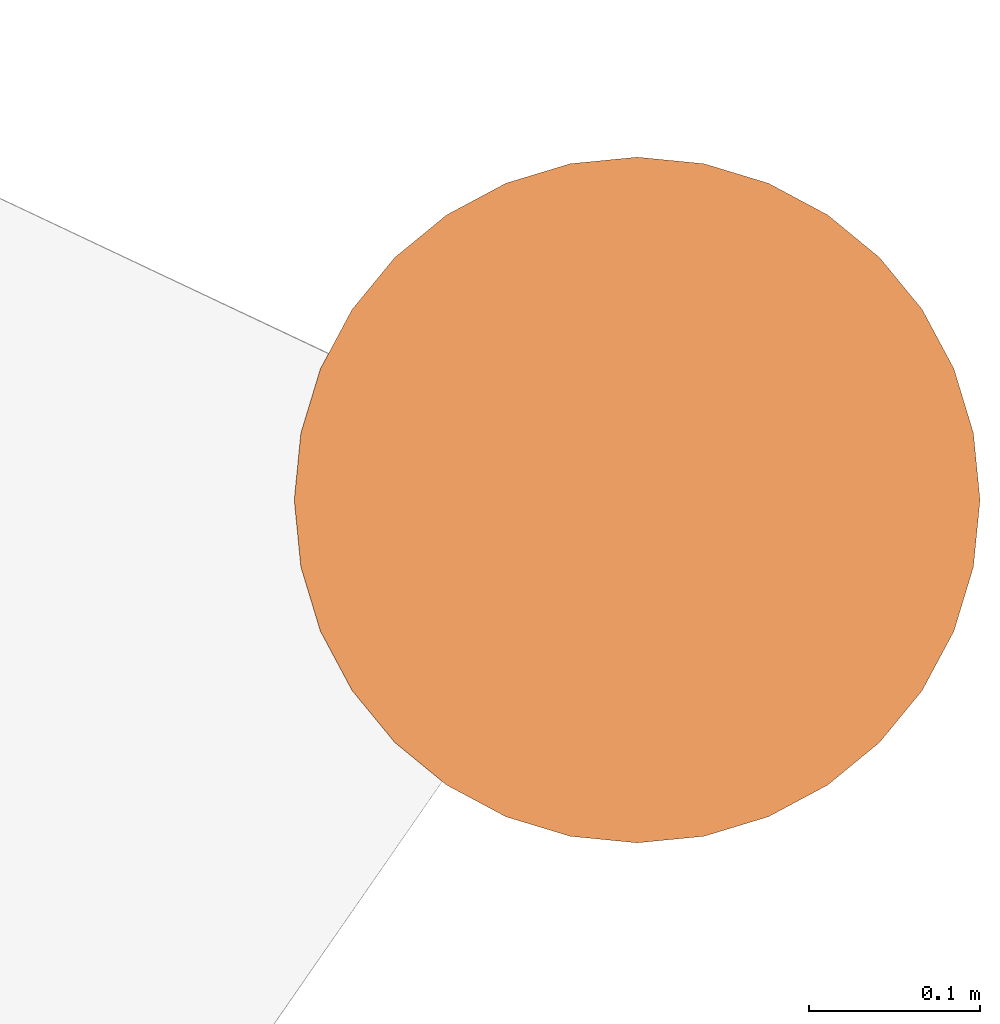
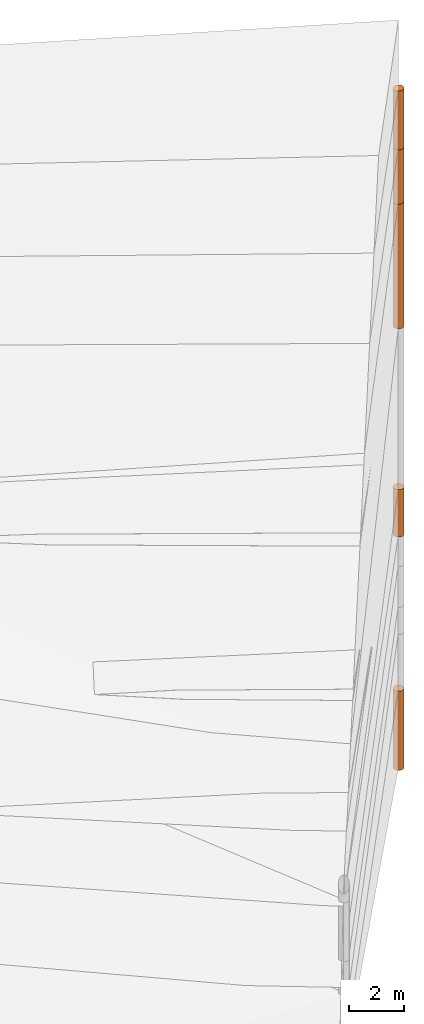
# One storey, part 20 of 24: 5 geographic elements.
"""IFC4 building model written with IfcOpenShell, lengths in metres."""

import ifcopenshell
import ifcopenshell.guid

model = None  # the IFC model being written
_history = None  # IfcOwnerHistory: only IFC2X3 demands one
_inside = {}  # id of a spatial element -> (the spatial element, [elements in it])
_under = {}  # id of a project, library or spatial element -> (it, [spatial elements below it])
_declared = {}  # id of a project -> (the project, [libraries it declares])
_typed = {}  # id of a type object -> (the type object, [elements of that type])
_made_of = {}  # id of a material, layer set ... -> (it, [elements and type objects made of it])


def new_model(schema):
    """Start an empty IFC model of exactly this schema.

    Asked for "IFC4X3", IfcOpenShell would pick the latest addendum, in which some entities
    have other attributes; the version numbers below select the first issue.
    IFC2X3 requires an IfcOwnerHistory on every rooted entity: one is made here for all.
    """
    global model, _history
    if schema == "IFC4X3":
        model = ifcopenshell.file(schema_version=(4, 3, 0, 0))
    else:
        model = ifcopenshell.file(schema=schema)
    _inside.clear()
    _under.clear()
    _declared.clear()
    _typed.clear()
    _made_of.clear()
    _history = None
    if model.schema == "IFC2X3":
        org = make("IfcOrganization", Name="unknown")
        user = make(
            "IfcPersonAndOrganization",
            ThePerson=make("IfcPerson", FamilyName="unknown"),
            TheOrganization=org,
        )
        app = make(
            "IfcApplication",
            ApplicationDeveloper=org,
            Version="unknown",
            ApplicationFullName="unknown",
            ApplicationIdentifier="unknown",
        )
        _history = make(
            "IfcOwnerHistory",
            OwningUser=user,
            OwningApplication=app,
            ChangeAction="ADDED",
            CreationDate=0,
        )
    return model


def make(cls, **values):
    """One entity of the class cls with the attributes given. An attribute that is None is left unset."""
    return model.create_entity(
        cls, **{name: value for name, value in values.items() if value is not None}
    )


def entity(cls, *values):
    """Any entity or typed value of the class cls, its attributes in the order of the schema. None: left unset."""
    e = model.create_entity(cls)
    for i, value in enumerate(values):
        if value is not None:
            e[i] = value
    return e


def rooted(cls, **values):
    """An entity with a GlobalId (a new one), such as an element, a storey or a relation."""
    return make(cls, GlobalId=ifcopenshell.guid.new(), OwnerHistory=_history, **values)


def si_unit(unit_type, name, prefix=None):
    """IfcSIUnit, for example si_unit("LENGTHUNIT", "METRE", prefix="MILLI")."""
    return make("IfcSIUnit", UnitType=unit_type, Prefix=prefix, Name=name)


def converted_unit(unit_type, name, factor, base, dimensions=None, offset=None):
    """IfcConversionBasedUnit, such as the inch: factor (a typed value) times the base unit."""
    return make(
        "IfcConversionBasedUnit"
        if offset is None
        else "IfcConversionBasedUnitWithOffset",
        ConversionOffset=offset,
        Dimensions=None
        if dimensions is None
        else entity("IfcDimensionalExponents", *dimensions),
        UnitType=unit_type,
        Name=name,
        ConversionFactor=make(
            "IfcMeasureWithUnit", ValueComponent=factor, UnitComponent=base
        ),
    )


def assignment(units):
    """IfcUnitAssignment: the units of a project."""
    return None if units is None else make("IfcUnitAssignment", Units=units)


def point(xyz):
    """IfcCartesianPoint."""
    return None if xyz is None else make("IfcCartesianPoint", Coordinates=xyz)


def direction(xyz):
    """IfcDirection."""
    return None if xyz is None else make("IfcDirection", DirectionRatios=xyz)


def frame(location, z_axis=None, x_axis=None):
    """IfcAxis2Placement3D, a coordinate frame: its origin and axes. An axis left out is left unset."""
    return make(
        "IfcAxis2Placement3D",
        Location=point(location),
        Axis=direction(z_axis),
        RefDirection=direction(x_axis),
    )


def frame_2d(location, x_axis=None):
    """IfcAxis2Placement2D, a coordinate frame in the plane: its origin and x axis."""
    return make(
        "IfcAxis2Placement2D", Location=point(location), RefDirection=direction(x_axis)
    )


def origin_with_axes():
    """The frame at (0, 0, 0) with the z axis (0, 0, 1) and the x axis (1, 0, 0) written out."""
    return frame((0.0, 0.0, 0.0), z_axis=(0.0, 0.0, 1.0), x_axis=(1.0, 0.0, 0.0))


def origin_2d_with_axis():
    """The frame at (0, 0) in the plane with the x axis (1, 0) written out."""
    return frame_2d((0.0, 0.0), x_axis=(1.0, 0.0))


def place(relative_to, where):
    """IfcLocalPlacement: puts the frame where relative to a parent placement (None: the world)."""
    return make(
        "IfcLocalPlacement", PlacementRelTo=relative_to, RelativePlacement=where
    )


def context(
    kind, dimensions, precision=None, world=None, true_north=None, identifier=None
):
    """IfcGeometricRepresentationContext, for example the 3D "Model" context."""
    return make(
        "IfcGeometricRepresentationContext",
        ContextIdentifier=identifier,
        ContextType=kind,
        CoordinateSpaceDimension=dimensions,
        Precision=precision,
        WorldCoordinateSystem=world,
        TrueNorth=true_north,
    )


def subcontext(parent, identifier, kind, view, scale=None):
    """IfcGeometricRepresentationSubContext, for example "Body" below "Model"."""
    return make(
        "IfcGeometricRepresentationSubContext",
        ContextIdentifier=identifier,
        ContextType=kind,
        ParentContext=parent,
        TargetScale=scale,
        TargetView=view,
    )


def project(units=None, contexts=None):
    """IfcProject with its units and contexts."""
    return rooted(
        "IfcProject",
        Name="project",
        RepresentationContexts=contexts,
        UnitsInContext=assignment(units),
    )


def spatial(cls, under=None, at=None, **own):
    """A site, building, storey or space (cls), placed at a placement, below another one or the project."""
    s = rooted(cls, ObjectPlacement=at, **own)
    if under is not None:
        _under.setdefault(under.id(), (under, []))[1].append(s)
    return s


def point_list(points):
    """IfcCartesianPointList2D or 3D."""
    cls = (
        "IfcCartesianPointList2D" if len(points[0]) == 2 else "IfcCartesianPointList3D"
    )
    return make(cls, CoordList=points)


def polygons(points, faces, closed=None, point_numbers=None):
    """IfcPolygonalFaceSet: a face is its outer loop, then its inner loops; points numbered from 1."""
    made = []
    for loops in faces:
        if len(loops) == 1:
            made.append(make("IfcIndexedPolygonalFace", CoordIndex=loops[0]))
        else:
            made.append(
                make(
                    "IfcIndexedPolygonalFaceWithVoids",
                    CoordIndex=loops[0],
                    InnerCoordIndices=loops[1:],
                )
            )
    return make(
        "IfcPolygonalFaceSet",
        Coordinates=point_list(points),
        Closed=closed,
        Faces=made,
        PnIndex=point_numbers,
    )


def shape(context_of_items, identifier, shape_type, items):
    """IfcShapeRepresentation: the items that make up one representation, for example the "Body"."""
    return make(
        "IfcShapeRepresentation",
        ContextOfItems=context_of_items,
        RepresentationIdentifier=identifier,
        RepresentationType=shape_type,
        Items=items,
    )


def made_of(thing, what):
    """Note that an element or type object is made of a material, layer set ...; save() writes the relation."""
    if what is not None:
        _made_of.setdefault(what.id(), (what, []))[1].append(thing)
    return thing


def element(
    cls,
    number,
    at=None,
    inside=None,
    cuts=None,
    type_object=None,
    material=None,
    context=None,
    identifier="Body",
    shape_type=None,
    held_by="IfcProductDefinitionShape",
    body=None,
    shapes=None,
    **own,
):
    """One element of the class cls, such as IfcWall. Its Tag is "e" and its number.

    at: its placement. inside: the storey or other place that contains it. cuts: it is an
    opening in that element (IfcRelVoidsElement). A single representation is given by context,
    identifier, shape_type and body (its items); several are given by shapes. held_by: the class
    of the entity that holds the representations. save() writes the other relations.
    """
    e = rooted(cls, Tag="e%d" % number, ObjectPlacement=at, **own)
    if body is not None:
        shapes = [shape(context, identifier, shape_type, body)]
    if shapes is not None:
        e.Representation = make(held_by, Representations=shapes)
    if inside is not None:
        _inside.setdefault(inside.id(), (inside, []))[1].append(e)
    if cuts is not None:
        rooted(
            "IfcRelVoidsElement", RelatingBuildingElement=cuts, RelatedOpeningElement=e
        )
    if type_object is not None:
        _typed.setdefault(type_object.id(), (type_object, []))[1].append(e)
    return made_of(e, material)


def aggregate(whole, parts):
    """IfcRelAggregates: a whole, such as a stair, and the parts it consists of."""
    return rooted("IfcRelAggregates", RelatingObject=whole, RelatedObjects=parts)


def save(model, path):
    """Write the relations noted so far, then the file.

    IfcRelAggregates (storeys below a building ...), IfcRelContainedInSpatialStructure (elements
    in a storey), IfcRelDefinesByType, IfcRelAssociatesMaterial and IfcRelDeclares: one each for
    every whole, place, type object, material and project.
    """
    for whole, parts in _under.values():
        aggregate(whole, parts)
    for where, things in _inside.values():
        rooted(
            "IfcRelContainedInSpatialStructure",
            RelatedElements=things,
            RelatingStructure=where,
        )
    for kind, things in _typed.values():
        rooted("IfcRelDefinesByType", RelatedObjects=things, RelatingType=kind)
    for what, things in _made_of.values():
        rooted("IfcRelAssociatesMaterial", RelatedObjects=things, RelatingMaterial=what)
    for by, libraries in _declared.values():
        rooted("IfcRelDeclares", RelatingContext=by, RelatedDefinitions=libraries)
    model.write(path)


model = new_model("IFC4")

# Units and contexts
model_context = context("Model", 3, precision=1e-05, world=origin_with_axes())
plan_context = context("Plan", 2, precision=1e-05, world=origin_2d_with_axis())
body_context = subcontext(model_context, "Body", "Model", "MODEL_VIEW")
ifc_project = project(units=[converted_unit("PLANEANGLEUNIT", "degree", entity("IfcReal", 0.0174532925199433), si_unit("PLANEANGLEUNIT", "RADIAN"), dimensions=[0, 0, 0, 0, 0, 0, 0]), si_unit("AREAUNIT", "SQUARE_METRE"), si_unit("VOLUMEUNIT", "CUBIC_METRE"), si_unit("LENGTHUNIT", "METRE")], contexts=[model_context, plan_context])

# Site, building, storey
site_placement = place(None, origin_with_axes())
site = spatial("IfcSite", under=ifc_project, at=site_placement)
building_placement = place(site_placement, origin_with_axes())
building = spatial("IfcBuilding", under=site, at=building_placement, Name="Building")
storey_placement = place(building_placement, origin_with_axes())
storey = spatial("IfcBuildingStorey", under=building, at=storey_placement, Name="Storey")

# Geographic elements
geographic_element_1_placement = place(storey_placement, frame((50.0999984741211, 76.4000015258789, -2.14999914169312), z_axis=(0.0, 0.0, 1.0), x_axis=(1.0, 0.0, 0.0)))
element("IfcGeographicElement", 1, at=geographic_element_1_placement, inside=storey, PredefinedType="NOTDEFINED", context=body_context, shape_type="Tessellation", body=[
    polygons([(0.0, 0.0, -1.04999983310699), (0.0390180610120296, 0.196157038211823, -1.04999983310699), (0.0, 0.199999988079071, -1.04999983310699), (0.0, 0.0, 1.04999983310699), (0.0, 0.199999988079071, 1.04999983310699), (0.0390180610120296, 0.196157038211823, 1.04999983310699), (0.0765366926789284, 0.18477588891983, -1.04999983310699), (0.0765366926789284, 0.18477588891983, 1.04999983310699), (0.111114047467709, 0.166293919086456, -1.04999983310699), (0.111114047467709, 0.166293919086456, 1.04999983310699), (0.141421362757683, 0.141421362757683, -1.04999983310699), (0.141421362757683, 0.141421362757683, 1.04999983310699), (0.166293919086456, 0.111114047467709, -1.04999983310699), (0.166293919086456, 0.111114047467709, 1.04999983310699), (0.18477588891983, 0.0765366926789284, -1.04999983310699), (0.18477588891983, 0.0765366926789284, 1.04999983310699), (0.196157038211823, 0.0390180610120296, -1.04999983310699), (0.196157038211823, 0.0390180610120296, 1.04999983310699), (0.199999988079071, 0.0, -1.04999983310699), (0.199999988079071, 0.0, 1.04999983310699), (0.196157038211823, -0.0390180610120296, -1.04999983310699), (0.196157038211823, -0.0390180610120296, 1.04999983310699), (0.18477588891983, -0.0765366926789284, -1.04999983310699), (0.18477588891983, -0.0765366926789284, 1.04999983310699), (0.166293919086456, -0.111114047467709, -1.04999983310699), (0.166293919086456, -0.111114047467709, 1.04999983310699), (0.141421362757683, -0.141421362757683, -1.04999983310699), (0.141421362757683, -0.141421362757683, 1.04999983310699), (0.111114047467709, -0.166293919086456, -1.04999983310699), (0.111114047467709, -0.166293919086456, 1.04999983310699), (0.0765366926789284, -0.18477588891983, -1.04999983310699), (0.0765366926789284, -0.18477588891983, 1.04999983310699), (0.0390180610120296, -0.196157038211823, -1.04999983310699), (0.0390180610120296, -0.196157038211823, 1.04999983310699), (0.0, -0.199999988079071, -1.04999983310699), (0.0, -0.199999988079071, 1.04999983310699), (-0.0390180610120296, -0.196157038211823, -1.04999983310699), (-0.0390180610120296, -0.196157038211823, 1.04999983310699), (-0.0765366926789284, -0.18477588891983, -1.04999983310699), (-0.0765366926789284, -0.18477588891983, 1.04999983310699), (-0.111114047467709, -0.166293919086456, -1.04999983310699), (-0.111114047467709, -0.166293919086456, 1.04999983310699), (-0.141421362757683, -0.141421362757683, -1.04999983310699), (-0.141421362757683, -0.141421362757683, 1.04999983310699), (-0.166293919086456, -0.111114047467709, -1.04999983310699), (-0.166293919086456, -0.111114047467709, 1.04999983310699), (-0.18477588891983, -0.0765366926789284, -1.04999983310699), (-0.18477588891983, -0.0765366926789284, 1.04999983310699), (-0.196157038211823, -0.0390180610120296, -1.04999983310699), (-0.196157038211823, -0.0390180610120296, 1.04999983310699), (-0.199999988079071, 0.0, -1.04999983310699), (-0.199999988079071, 0.0, 1.04999983310699), (-0.196157038211823, 0.0390180610120296, -1.04999983310699), (-0.196157038211823, 0.0390180610120296, 1.04999983310699), (-0.18477588891983, 0.0765366926789284, -1.04999983310699), (-0.18477588891983, 0.0765366926789284, 1.04999983310699), (-0.166293919086456, 0.111114047467709, -1.04999983310699), (-0.166293919086456, 0.111114047467709, 1.04999983310699), (-0.141421362757683, 0.141421362757683, -1.04999983310699), (-0.141421362757683, 0.141421362757683, 1.04999983310699), (-0.111114047467709, 0.166293919086456, -1.04999983310699), (-0.111114047467709, 0.166293919086456, 1.04999983310699), (-0.0765366926789284, 0.18477588891983, -1.04999983310699), (-0.0765366926789284, 0.18477588891983, 1.04999983310699), (-0.0390180610120296, 0.196157038211823, -1.04999983310699), (-0.0390180610120296, 0.196157038211823, 1.04999983310699)], [[[3, 2, 1]], [[6, 5, 4]], [[34, 36, 35, 33]], [[2, 7, 1]], [[8, 6, 4]], [[54, 56, 55, 53]], [[7, 9, 1]], [[10, 8, 4]], [[10, 12, 11, 9]], [[9, 11, 1]], [[12, 10, 4]], [[11, 13, 1]], [[12, 4, 14]], [[46, 48, 47, 45]], [[1, 13, 15]], [[4, 16, 14]], [[28, 30, 29, 27]], [[1, 15, 17]], [[16, 4, 18]], [[38, 40, 39, 37]], [[1, 17, 19]], [[4, 20, 18]], [[20, 22, 21, 19]], [[1, 19, 21]], [[20, 4, 22]], [[22, 24, 23, 21]], [[1, 21, 23]], [[22, 4, 24]], [[5, 6, 2, 3]], [[1, 23, 25]], [[24, 4, 26]], [[58, 60, 59, 57]], [[1, 25, 27]], [[26, 4, 28]], [[24, 26, 25, 23]], [[1, 27, 29]], [[28, 4, 30]], [[8, 10, 9, 7]], [[1, 29, 31]], [[4, 32, 30]], [[60, 62, 61, 59]], [[1, 31, 33]], [[4, 34, 32]], [[64, 66, 65, 63]], [[1, 33, 35]], [[4, 36, 34]], [[26, 28, 27, 25]], [[1, 35, 37]], [[4, 38, 36]], [[32, 34, 33, 31]], [[1, 37, 39]], [[4, 40, 38]], [[36, 38, 37, 35]], [[1, 39, 41]], [[4, 42, 40]], [[42, 44, 43, 41]], [[43, 1, 41]], [[4, 44, 42]], [[44, 46, 45, 43]], [[45, 1, 43]], [[4, 46, 44]], [[12, 14, 13, 11]], [[47, 1, 45]], [[48, 46, 4]], [[14, 16, 15, 13]], [[49, 1, 47]], [[4, 50, 48]], [[50, 52, 51, 49]], [[51, 1, 49]], [[52, 50, 4]], [[66, 5, 3, 65]], [[51, 53, 1]], [[4, 54, 52]], [[6, 8, 7, 2]], [[55, 1, 53]], [[4, 56, 54]], [[16, 18, 17, 15]], [[55, 57, 1]], [[4, 58, 56]], [[30, 32, 31, 29]], [[59, 1, 57]], [[60, 58, 4]], [[56, 58, 57, 55]], [[59, 61, 1]], [[62, 60, 4]], [[62, 64, 63, 61]], [[61, 63, 1]], [[64, 62, 4]], [[40, 42, 41, 39]], [[63, 65, 1]], [[66, 64, 4]], [[18, 20, 19, 17]], [[65, 3, 1]], [[5, 66, 4]], [[52, 54, 53, 51]], [[48, 50, 49, 47]]]),
])
geographic_element_2_placement = place(storey_placement, frame((50.0999984741211, 76.4000015258789, 8.75000095367432), z_axis=(0.0, 0.0, 1.0), x_axis=(1.0, 0.0, 0.0)))
element("IfcGeographicElement", 2, at=geographic_element_2_placement, inside=storey, PredefinedType="NOTDEFINED", context=body_context, shape_type="Tessellation", body=[
    polygons([(0.0, 0.0, -2.74999976158142), (0.0390180610120296, 0.196157038211823, -2.74999976158142), (0.0, 0.199999988079071, -2.74999976158142), (0.0, 0.0, 2.74999976158142), (0.0, 0.199999988079071, 2.74999976158142), (0.0390180610120296, 0.196157038211823, 2.74999976158142), (0.0765366926789284, 0.18477588891983, -2.74999976158142), (0.0765366926789284, 0.18477588891983, 2.74999976158142), (0.111114047467709, 0.166293919086456, -2.74999976158142), (0.111114047467709, 0.166293919086456, 2.74999976158142), (0.141421362757683, 0.141421362757683, -2.74999976158142), (0.141421362757683, 0.141421362757683, 2.74999976158142), (0.166293919086456, 0.111114047467709, -2.74999976158142), (0.166293919086456, 0.111114047467709, 2.74999976158142), (0.18477588891983, 0.0765366926789284, -2.74999976158142), (0.18477588891983, 0.0765366926789284, 2.74999976158142), (0.196157038211823, 0.0390180610120296, -2.74999976158142), (0.196157038211823, 0.0390180610120296, 2.74999976158142), (0.199999988079071, 0.0, -2.74999976158142), (0.199999988079071, 0.0, 2.74999976158142), (0.196157038211823, -0.0390180610120296, -2.74999976158142), (0.196157038211823, -0.0390180610120296, 2.74999976158142), (0.18477588891983, -0.0765366926789284, -2.74999976158142), (0.18477588891983, -0.0765366926789284, 2.74999976158142), (0.166293919086456, -0.111114047467709, -2.74999976158142), (0.166293919086456, -0.111114047467709, 2.74999976158142), (0.141421362757683, -0.141421362757683, -2.74999976158142), (0.141421362757683, -0.141421362757683, 2.74999976158142), (0.111114047467709, -0.166293919086456, -2.74999976158142), (0.111114047467709, -0.166293919086456, 2.74999976158142), (0.0765366926789284, -0.18477588891983, -2.74999976158142), (0.0765366926789284, -0.18477588891983, 2.74999976158142), (0.0390180610120296, -0.196157038211823, -2.74999976158142), (0.0390180610120296, -0.196157038211823, 2.74999976158142), (0.0, -0.199999988079071, -2.74999976158142), (0.0, -0.199999988079071, 2.74999976158142), (-0.0390180610120296, -0.196157038211823, -2.74999976158142), (-0.0390180610120296, -0.196157038211823, 2.74999976158142), (-0.0765366926789284, -0.18477588891983, -2.74999976158142), (-0.0765366926789284, -0.18477588891983, 2.74999976158142), (-0.111114047467709, -0.166293919086456, -2.74999976158142), (-0.111114047467709, -0.166293919086456, 2.74999976158142), (-0.141421362757683, -0.141421362757683, -2.74999976158142), (-0.141421362757683, -0.141421362757683, 2.74999976158142), (-0.166293919086456, -0.111114047467709, -2.74999976158142), (-0.166293919086456, -0.111114047467709, 2.74999976158142), (-0.18477588891983, -0.0765366926789284, -2.74999976158142), (-0.18477588891983, -0.0765366926789284, 2.74999976158142), (-0.196157038211823, -0.0390180610120296, -2.74999976158142), (-0.196157038211823, -0.0390180610120296, 2.74999976158142), (-0.199999988079071, 0.0, -2.74999976158142), (-0.199999988079071, 0.0, 2.74999976158142), (-0.196157038211823, 0.0390180610120296, -2.74999976158142), (-0.196157038211823, 0.0390180610120296, 2.74999976158142), (-0.18477588891983, 0.0765366926789284, -2.74999976158142), (-0.18477588891983, 0.0765366926789284, 2.74999976158142), (-0.166293919086456, 0.111114047467709, -2.74999976158142), (-0.166293919086456, 0.111114047467709, 2.74999976158142), (-0.141421362757683, 0.141421362757683, -2.74999976158142), (-0.141421362757683, 0.141421362757683, 2.74999976158142), (-0.111114047467709, 0.166293919086456, -2.74999976158142), (-0.111114047467709, 0.166293919086456, 2.74999976158142), (-0.0765366926789284, 0.18477588891983, -2.74999976158142), (-0.0765366926789284, 0.18477588891983, 2.74999976158142), (-0.0390180610120296, 0.196157038211823, -2.74999976158142), (-0.0390180610120296, 0.196157038211823, 2.74999976158142)], [[[3, 2, 1]], [[6, 5, 4]], [[28, 30, 29, 27]], [[2, 7, 1]], [[8, 6, 4]], [[64, 66, 65, 63]], [[7, 9, 1]], [[10, 8, 4]], [[9, 11, 1]], [[12, 10, 4]], [[6, 8, 7, 2]], [[1, 11, 13]], [[12, 4, 14]], [[66, 5, 3, 65]], [[1, 13, 15]], [[4, 16, 14]], [[12, 14, 13, 11]], [[1, 15, 17]], [[16, 4, 18]], [[14, 16, 15, 13]], [[1, 17, 19]], [[4, 20, 18]], [[16, 18, 17, 15]], [[1, 19, 21]], [[20, 4, 22]], [[18, 20, 19, 17]], [[1, 21, 23]], [[4, 24, 22]], [[20, 22, 21, 19]], [[1, 23, 25]], [[4, 26, 24]], [[22, 24, 23, 21]], [[1, 25, 27]], [[4, 28, 26]], [[24, 26, 25, 23]], [[1, 27, 29]], [[28, 4, 30]], [[26, 28, 27, 25]], [[1, 29, 31]], [[4, 32, 30]], [[5, 6, 2, 3]], [[1, 31, 33]], [[4, 34, 32]], [[30, 32, 31, 29]], [[1, 33, 35]], [[4, 36, 34]], [[8, 10, 9, 7]], [[1, 35, 37]], [[4, 38, 36]], [[32, 34, 33, 31]], [[1, 37, 39]], [[4, 40, 38]], [[36, 38, 37, 35]], [[1, 39, 41]], [[4, 42, 40]], [[38, 40, 39, 37]], [[43, 1, 41]], [[4, 44, 42]], [[40, 42, 41, 39]], [[43, 45, 1]], [[4, 46, 44]], [[42, 44, 43, 41]], [[45, 47, 1]], [[48, 46, 4]], [[44, 46, 45, 43]], [[47, 49, 1]], [[4, 50, 48]], [[46, 48, 47, 45]], [[51, 1, 49]], [[52, 50, 4]], [[48, 50, 49, 47]], [[51, 53, 1]], [[4, 54, 52]], [[50, 52, 51, 49]], [[55, 1, 53]], [[56, 54, 4]], [[52, 54, 53, 51]], [[55, 57, 1]], [[58, 56, 4]], [[54, 56, 55, 53]], [[59, 1, 57]], [[60, 58, 4]], [[56, 58, 57, 55]], [[59, 61, 1]], [[62, 60, 4]], [[58, 60, 59, 57]], [[61, 63, 1]], [[64, 62, 4]], [[60, 62, 61, 59]], [[63, 65, 1]], [[66, 64, 4]], [[62, 64, 63, 61]], [[65, 3, 1]], [[5, 66, 4]], [[34, 36, 35, 33]], [[10, 12, 11, 9]]]),
])
geographic_element_3_placement = place(storey_placement, frame((50.0999984741211, 76.4000015258789, 12.7000007629395), z_axis=(0.0, 0.0, 1.0), x_axis=(1.0, 0.0, 0.0)))
element("IfcGeographicElement", 3, at=geographic_element_3_placement, inside=storey, PredefinedType="NOTDEFINED", context=body_context, shape_type="Tessellation", body=[
    polygons([(0.0, 0.0, -1.19999992847443), (0.0390180610120296, 0.196157038211823, -1.19999992847443), (0.0, 0.199999988079071, -1.19999992847443), (0.0, 0.0, 1.19999992847443), (0.0, 0.199999988079071, 1.19999992847443), (0.0390180610120296, 0.196157038211823, 1.19999992847443), (0.0765366926789284, 0.18477588891983, -1.19999992847443), (0.0765366926789284, 0.18477588891983, 1.19999992847443), (0.111114047467709, 0.166293919086456, -1.19999992847443), (0.111114047467709, 0.166293919086456, 1.19999992847443), (0.141421362757683, 0.141421362757683, -1.19999992847443), (0.141421362757683, 0.141421362757683, 1.19999992847443), (0.166293919086456, 0.111114047467709, -1.19999992847443), (0.166293919086456, 0.111114047467709, 1.19999992847443), (0.18477588891983, 0.0765366926789284, -1.19999992847443), (0.18477588891983, 0.0765366926789284, 1.19999992847443), (0.196157038211823, 0.0390180610120296, -1.19999992847443), (0.196157038211823, 0.0390180610120296, 1.19999992847443), (0.199999988079071, 0.0, -1.19999992847443), (0.199999988079071, 0.0, 1.19999992847443), (0.196157038211823, -0.0390180610120296, -1.19999992847443), (0.196157038211823, -0.0390180610120296, 1.19999992847443), (0.18477588891983, -0.0765366926789284, -1.19999992847443), (0.18477588891983, -0.0765366926789284, 1.19999992847443), (0.166293919086456, -0.111114047467709, -1.19999992847443), (0.166293919086456, -0.111114047467709, 1.19999992847443), (0.141421362757683, -0.141421362757683, -1.19999992847443), (0.141421362757683, -0.141421362757683, 1.19999992847443), (0.111114047467709, -0.166293919086456, -1.19999992847443), (0.111114047467709, -0.166293919086456, 1.19999992847443), (0.0765366926789284, -0.18477588891983, -1.19999992847443), (0.0765366926789284, -0.18477588891983, 1.19999992847443), (0.0390180610120296, -0.196157038211823, -1.19999992847443), (0.0390180610120296, -0.196157038211823, 1.19999992847443), (0.0, -0.199999988079071, -1.19999992847443), (0.0, -0.199999988079071, 1.19999992847443), (-0.0390180610120296, -0.196157038211823, -1.19999992847443), (-0.0390180610120296, -0.196157038211823, 1.19999992847443), (-0.0765366926789284, -0.18477588891983, -1.19999992847443), (-0.0765366926789284, -0.18477588891983, 1.19999992847443), (-0.111114047467709, -0.166293919086456, -1.19999992847443), (-0.111114047467709, -0.166293919086456, 1.19999992847443), (-0.141421362757683, -0.141421362757683, -1.19999992847443), (-0.141421362757683, -0.141421362757683, 1.19999992847443), (-0.166293919086456, -0.111114047467709, -1.19999992847443), (-0.166293919086456, -0.111114047467709, 1.19999992847443), (-0.18477588891983, -0.0765366926789284, -1.19999992847443), (-0.18477588891983, -0.0765366926789284, 1.19999992847443), (-0.196157038211823, -0.0390180610120296, -1.19999992847443), (-0.196157038211823, -0.0390180610120296, 1.19999992847443), (-0.199999988079071, 0.0, -1.19999992847443), (-0.199999988079071, 0.0, 1.19999992847443), (-0.196157038211823, 0.0390180610120296, -1.19999992847443), (-0.196157038211823, 0.0390180610120296, 1.19999992847443), (-0.18477588891983, 0.0765366926789284, -1.19999992847443), (-0.18477588891983, 0.0765366926789284, 1.19999992847443), (-0.166293919086456, 0.111114047467709, -1.19999992847443), (-0.166293919086456, 0.111114047467709, 1.19999992847443), (-0.141421362757683, 0.141421362757683, -1.19999992847443), (-0.141421362757683, 0.141421362757683, 1.19999992847443), (-0.111114047467709, 0.166293919086456, -1.19999992847443), (-0.111114047467709, 0.166293919086456, 1.19999992847443), (-0.0765366926789284, 0.18477588891983, -1.19999992847443), (-0.0765366926789284, 0.18477588891983, 1.19999992847443), (-0.0390180610120296, 0.196157038211823, -1.19999992847443), (-0.0390180610120296, 0.196157038211823, 1.19999992847443)], [[[3, 2, 1]], [[6, 5, 4]], [[62, 64, 63, 61]], [[2, 7, 1]], [[8, 6, 4]], [[30, 32, 31, 29]], [[7, 9, 1]], [[10, 8, 4]], [[10, 12, 11, 9]], [[9, 11, 1]], [[12, 10, 4]], [[11, 13, 1]], [[12, 4, 14]], [[66, 5, 3, 65]], [[1, 13, 15]], [[4, 16, 14]], [[42, 44, 43, 41]], [[1, 15, 17]], [[16, 4, 18]], [[48, 50, 49, 47]], [[1, 17, 19]], [[4, 20, 18]], [[16, 18, 17, 15]], [[1, 19, 21]], [[20, 4, 22]], [[50, 52, 51, 49]], [[1, 21, 23]], [[22, 4, 24]], [[54, 56, 55, 53]], [[1, 23, 25]], [[4, 26, 24]], [[56, 58, 57, 55]], [[27, 1, 25]], [[26, 4, 28]], [[58, 60, 59, 57]], [[1, 27, 29]], [[28, 4, 30]], [[60, 62, 61, 59]], [[1, 29, 31]], [[4, 32, 30]], [[64, 66, 65, 63]], [[1, 31, 33]], [[4, 34, 32]], [[6, 8, 7, 2]], [[1, 33, 35]], [[4, 36, 34]], [[8, 10, 9, 7]], [[1, 35, 37]], [[4, 38, 36]], [[32, 34, 33, 31]], [[1, 37, 39]], [[4, 40, 38]], [[36, 38, 37, 35]], [[1, 39, 41]], [[4, 42, 40]], [[46, 48, 47, 45]], [[43, 1, 41]], [[4, 44, 42]], [[34, 36, 35, 33]], [[45, 1, 43]], [[46, 44, 4]], [[14, 16, 15, 13]], [[45, 47, 1]], [[48, 46, 4]], [[44, 46, 45, 43]], [[49, 1, 47]], [[4, 50, 48]], [[40, 42, 41, 39]], [[51, 1, 49]], [[52, 50, 4]], [[18, 20, 19, 17]], [[51, 53, 1]], [[4, 54, 52]], [[20, 22, 21, 19]], [[55, 1, 53]], [[4, 56, 54]], [[52, 54, 53, 51]], [[55, 57, 1]], [[58, 56, 4]], [[22, 24, 23, 21]], [[57, 59, 1]], [[60, 58, 4]], [[24, 26, 25, 23]], [[59, 61, 1]], [[62, 60, 4]], [[26, 28, 27, 25]], [[61, 63, 1]], [[64, 62, 4]], [[28, 30, 29, 27]], [[63, 65, 1]], [[66, 64, 4]], [[5, 6, 2, 3]], [[65, 3, 1]], [[5, 66, 4]], [[38, 40, 39, 37]], [[12, 14, 13, 11]]]),
])
geographic_element_4_placement = place(storey_placement, frame((50.0999984741211, 76.4000015258789, 15.2000007629395), z_axis=(0.0, 0.0, 1.0), x_axis=(1.0, 0.0, 0.0)))
element("IfcGeographicElement", 4, at=geographic_element_4_placement, inside=storey, PredefinedType="NOTDEFINED", context=body_context, shape_type="Tessellation", body=[
    polygons([(0.0, 0.0, -1.29999983310699), (0.0390180610120296, 0.196157038211823, -1.29999983310699), (0.0, 0.199999988079071, -1.29999983310699), (0.0, 0.0, 1.29999983310699), (0.0, 0.199999988079071, 1.29999983310699), (0.0390180610120296, 0.196157038211823, 1.29999983310699), (0.0765366926789284, 0.18477588891983, -1.29999983310699), (0.0765366926789284, 0.18477588891983, 1.29999983310699), (0.111114047467709, 0.166293919086456, -1.29999983310699), (0.111114047467709, 0.166293919086456, 1.29999983310699), (0.141421362757683, 0.141421362757683, -1.29999983310699), (0.141421362757683, 0.141421362757683, 1.29999983310699), (0.166293919086456, 0.111114047467709, -1.29999983310699), (0.166293919086456, 0.111114047467709, 1.29999983310699), (0.18477588891983, 0.0765366926789284, -1.29999983310699), (0.18477588891983, 0.0765366926789284, 1.29999983310699), (0.196157038211823, 0.0390180610120296, -1.29999983310699), (0.196157038211823, 0.0390180610120296, 1.29999983310699), (0.199999988079071, 0.0, -1.29999983310699), (0.199999988079071, 0.0, 1.29999983310699), (0.196157038211823, -0.0390180610120296, -1.29999983310699), (0.196157038211823, -0.0390180610120296, 1.29999983310699), (0.18477588891983, -0.0765366926789284, -1.29999983310699), (0.18477588891983, -0.0765366926789284, 1.29999983310699), (0.166293919086456, -0.111114047467709, -1.29999983310699), (0.166293919086456, -0.111114047467709, 1.29999983310699), (0.141421362757683, -0.141421362757683, -1.29999983310699), (0.141421362757683, -0.141421362757683, 1.29999983310699), (0.111114047467709, -0.166293919086456, -1.29999983310699), (0.111114047467709, -0.166293919086456, 1.29999983310699), (0.0765366926789284, -0.18477588891983, -1.29999983310699), (0.0765366926789284, -0.18477588891983, 1.29999983310699), (0.0390180610120296, -0.196157038211823, -1.29999983310699), (0.0390180610120296, -0.196157038211823, 1.29999983310699), (0.0, -0.199999988079071, -1.29999983310699), (0.0, -0.199999988079071, 1.29999983310699), (-0.0390180610120296, -0.196157038211823, -1.29999983310699), (-0.0390180610120296, -0.196157038211823, 1.29999983310699), (-0.0765366926789284, -0.18477588891983, -1.29999983310699), (-0.0765366926789284, -0.18477588891983, 1.29999983310699), (-0.111114047467709, -0.166293919086456, -1.29999983310699), (-0.111114047467709, -0.166293919086456, 1.29999983310699), (-0.141421362757683, -0.141421362757683, -1.29999983310699), (-0.141421362757683, -0.141421362757683, 1.29999983310699), (-0.166293919086456, -0.111114047467709, -1.29999983310699), (-0.166293919086456, -0.111114047467709, 1.29999983310699), (-0.18477588891983, -0.0765366926789284, -1.29999983310699), (-0.18477588891983, -0.0765366926789284, 1.29999983310699), (-0.196157038211823, -0.0390180610120296, -1.29999983310699), (-0.196157038211823, -0.0390180610120296, 1.29999983310699), (-0.199999988079071, 0.0, -1.29999983310699), (-0.199999988079071, 0.0, 1.29999983310699), (-0.196157038211823, 0.0390180610120296, -1.29999983310699), (-0.196157038211823, 0.0390180610120296, 1.29999983310699), (-0.18477588891983, 0.0765366926789284, -1.29999983310699), (-0.18477588891983, 0.0765366926789284, 1.29999983310699), (-0.166293919086456, 0.111114047467709, -1.29999983310699), (-0.166293919086456, 0.111114047467709, 1.29999983310699), (-0.141421362757683, 0.141421362757683, -1.29999983310699), (-0.141421362757683, 0.141421362757683, 1.29999983310699), (-0.111114047467709, 0.166293919086456, -1.29999983310699), (-0.111114047467709, 0.166293919086456, 1.29999983310699), (-0.0765366926789284, 0.18477588891983, -1.29999983310699), (-0.0765366926789284, 0.18477588891983, 1.29999983310699), (-0.0390180610120296, 0.196157038211823, -1.29999983310699), (-0.0390180610120296, 0.196157038211823, 1.29999983310699)], [[[3, 2, 1]], [[6, 5, 4]], [[32, 34, 33, 31]], [[2, 7, 1]], [[8, 6, 4]], [[64, 66, 65, 63]], [[7, 9, 1]], [[10, 8, 4]], [[9, 11, 1]], [[12, 10, 4]], [[40, 42, 41, 39]], [[1, 11, 13]], [[12, 4, 14]], [[10, 12, 11, 9]], [[1, 13, 15]], [[4, 16, 14]], [[12, 14, 13, 11]], [[1, 15, 17]], [[4, 18, 16]], [[18, 20, 19, 17]], [[1, 17, 19]], [[18, 4, 20]], [[20, 22, 21, 19]], [[1, 19, 21]], [[20, 4, 22]], [[22, 24, 23, 21]], [[1, 21, 23]], [[4, 24, 22]], [[54, 56, 55, 53]], [[1, 23, 25]], [[4, 26, 24]], [[56, 58, 57, 55]], [[27, 1, 25]], [[4, 28, 26]], [[24, 26, 25, 23]], [[1, 27, 29]], [[28, 4, 30]], [[26, 28, 27, 25]], [[1, 29, 31]], [[4, 32, 30]], [[46, 48, 47, 45]], [[1, 31, 33]], [[4, 34, 32]], [[36, 38, 37, 35]], [[1, 33, 35]], [[4, 36, 34]], [[42, 44, 43, 41]], [[1, 35, 37]], [[4, 38, 36]], [[38, 40, 39, 37]], [[1, 37, 39]], [[4, 40, 38]], [[34, 36, 35, 33]], [[1, 39, 41]], [[4, 42, 40]], [[8, 10, 9, 7]], [[43, 1, 41]], [[4, 44, 42]], [[44, 46, 45, 43]], [[43, 45, 1]], [[46, 44, 4]], [[30, 32, 31, 29]], [[45, 47, 1]], [[48, 46, 4]], [[28, 30, 29, 27]], [[47, 49, 1]], [[50, 48, 4]], [[5, 6, 2, 3]], [[51, 1, 49]], [[4, 52, 50]], [[48, 50, 49, 47]], [[53, 1, 51]], [[4, 54, 52]], [[50, 52, 51, 49]], [[53, 55, 1]], [[56, 54, 4]], [[52, 54, 53, 51]], [[55, 57, 1]], [[58, 56, 4]], [[58, 60, 59, 57]], [[57, 59, 1]], [[60, 58, 4]], [[60, 62, 61, 59]], [[59, 61, 1]], [[62, 60, 4]], [[62, 64, 63, 61]], [[61, 63, 1]], [[64, 62, 4]], [[14, 16, 15, 13]], [[63, 65, 1]], [[66, 64, 4]], [[16, 18, 17, 15]], [[65, 3, 1]], [[5, 66, 4]], [[6, 8, 7, 2]], [[66, 5, 3, 65]]]),
])
geographic_element_5_placement = place(storey_placement, frame((50.0999984741211, 76.4000015258789, -11.7499990463257), z_axis=(0.0, 0.0, 1.0), x_axis=(1.0, 0.0, 0.0)))
element("IfcGeographicElement", 5, at=geographic_element_5_placement, inside=storey, PredefinedType="NOTDEFINED", context=body_context, shape_type="Tessellation", body=[
    polygons([(0.0, 0.0, -1.74999988079071), (0.0390180610120296, 0.196157038211823, -1.74999988079071), (0.0, 0.199999988079071, -1.74999988079071), (0.0, 0.0, 1.74999988079071), (0.0, 0.199999988079071, 1.74999988079071), (0.0390180610120296, 0.196157038211823, 1.74999988079071), (0.0765366926789284, 0.18477588891983, -1.74999988079071), (0.0765366926789284, 0.18477588891983, 1.74999988079071), (0.111114047467709, 0.166293919086456, -1.74999988079071), (0.111114047467709, 0.166293919086456, 1.74999988079071), (0.141421362757683, 0.141421362757683, -1.74999988079071), (0.141421362757683, 0.141421362757683, 1.74999988079071), (0.166293919086456, 0.111114047467709, -1.74999988079071), (0.166293919086456, 0.111114047467709, 1.74999988079071), (0.18477588891983, 0.0765366926789284, -1.74999988079071), (0.18477588891983, 0.0765366926789284, 1.74999988079071), (0.196157038211823, 0.0390180610120296, -1.74999988079071), (0.196157038211823, 0.0390180610120296, 1.74999988079071), (0.199999988079071, 0.0, -1.74999988079071), (0.199999988079071, 0.0, 1.74999988079071), (0.196157038211823, -0.0390180610120296, -1.74999988079071), (0.196157038211823, -0.0390180610120296, 1.74999988079071), (0.18477588891983, -0.0765366926789284, -1.74999988079071), (0.18477588891983, -0.0765366926789284, 1.74999988079071), (0.166293919086456, -0.111114047467709, -1.74999988079071), (0.166293919086456, -0.111114047467709, 1.74999988079071), (0.141421362757683, -0.141421362757683, -1.74999988079071), (0.141421362757683, -0.141421362757683, 1.74999988079071), (0.111114047467709, -0.166293919086456, -1.74999988079071), (0.111114047467709, -0.166293919086456, 1.74999988079071), (0.0765366926789284, -0.18477588891983, -1.74999988079071), (0.0765366926789284, -0.18477588891983, 1.74999988079071), (0.0390180610120296, -0.196157038211823, -1.74999988079071), (0.0390180610120296, -0.196157038211823, 1.74999988079071), (0.0, -0.199999988079071, -1.74999988079071), (0.0, -0.199999988079071, 1.74999988079071), (-0.0390180610120296, -0.196157038211823, -1.74999988079071), (-0.0390180610120296, -0.196157038211823, 1.74999988079071), (-0.0765366926789284, -0.18477588891983, -1.74999988079071), (-0.0765366926789284, -0.18477588891983, 1.74999988079071), (-0.111114047467709, -0.166293919086456, -1.74999988079071), (-0.111114047467709, -0.166293919086456, 1.74999988079071), (-0.141421362757683, -0.141421362757683, -1.74999988079071), (-0.141421362757683, -0.141421362757683, 1.74999988079071), (-0.166293919086456, -0.111114047467709, -1.74999988079071), (-0.166293919086456, -0.111114047467709, 1.74999988079071), (-0.18477588891983, -0.0765366926789284, -1.74999988079071), (-0.18477588891983, -0.0765366926789284, 1.74999988079071), (-0.196157038211823, -0.0390180610120296, -1.74999988079071), (-0.196157038211823, -0.0390180610120296, 1.74999988079071), (-0.199999988079071, 0.0, -1.74999988079071), (-0.199999988079071, 0.0, 1.74999988079071), (-0.196157038211823, 0.0390180610120296, -1.74999988079071), (-0.196157038211823, 0.0390180610120296, 1.74999988079071), (-0.18477588891983, 0.0765366926789284, -1.74999988079071), (-0.18477588891983, 0.0765366926789284, 1.74999988079071), (-0.166293919086456, 0.111114047467709, -1.74999988079071), (-0.166293919086456, 0.111114047467709, 1.74999988079071), (-0.141421362757683, 0.141421362757683, -1.74999988079071), (-0.141421362757683, 0.141421362757683, 1.74999988079071), (-0.111114047467709, 0.166293919086456, -1.74999988079071), (-0.111114047467709, 0.166293919086456, 1.74999988079071), (-0.0765366926789284, 0.18477588891983, -1.74999988079071), (-0.0765366926789284, 0.18477588891983, 1.74999988079071), (-0.0390180610120296, 0.196157038211823, -1.74999988079071), (-0.0390180610120296, 0.196157038211823, 1.74999988079071)], [[[3, 2, 1]], [[6, 5, 4]], [[28, 30, 29, 27]], [[2, 7, 1]], [[8, 6, 4]], [[64, 66, 65, 63]], [[7, 9, 1]], [[10, 8, 4]], [[9, 11, 1]], [[12, 10, 4]], [[6, 8, 7, 2]], [[1, 11, 13]], [[12, 4, 14]], [[66, 5, 3, 65]], [[1, 13, 15]], [[14, 4, 16]], [[12, 14, 13, 11]], [[1, 15, 17]], [[16, 4, 18]], [[14, 16, 15, 13]], [[1, 17, 19]], [[4, 20, 18]], [[16, 18, 17, 15]], [[1, 19, 21]], [[20, 4, 22]], [[18, 20, 19, 17]], [[1, 21, 23]], [[4, 24, 22]], [[20, 22, 21, 19]], [[1, 23, 25]], [[4, 26, 24]], [[22, 24, 23, 21]], [[27, 1, 25]], [[4, 28, 26]], [[24, 26, 25, 23]], [[1, 27, 29]], [[28, 4, 30]], [[26, 28, 27, 25]], [[1, 29, 31]], [[4, 32, 30]], [[5, 6, 2, 3]], [[1, 31, 33]], [[4, 34, 32]], [[30, 32, 31, 29]], [[1, 33, 35]], [[4, 36, 34]], [[8, 10, 9, 7]], [[1, 35, 37]], [[4, 38, 36]], [[32, 34, 33, 31]], [[1, 37, 39]], [[4, 40, 38]], [[36, 38, 37, 35]], [[1, 39, 41]], [[4, 42, 40]], [[38, 40, 39, 37]], [[43, 1, 41]], [[4, 44, 42]], [[40, 42, 41, 39]], [[43, 45, 1]], [[46, 44, 4]], [[42, 44, 43, 41]], [[45, 47, 1]], [[4, 48, 46]], [[44, 46, 45, 43]], [[47, 49, 1]], [[4, 50, 48]], [[46, 48, 47, 45]], [[51, 1, 49]], [[52, 50, 4]], [[48, 50, 49, 47]], [[51, 53, 1]], [[4, 54, 52]], [[50, 52, 51, 49]], [[55, 1, 53]], [[56, 54, 4]], [[52, 54, 53, 51]], [[57, 1, 55]], [[58, 56, 4]], [[54, 56, 55, 53]], [[57, 59, 1]], [[60, 58, 4]], [[56, 58, 57, 55]], [[59, 61, 1]], [[62, 60, 4]], [[58, 60, 59, 57]], [[61, 63, 1]], [[64, 62, 4]], [[60, 62, 61, 59]], [[63, 65, 1]], [[66, 64, 4]], [[62, 64, 63, 61]], [[65, 3, 1]], [[5, 66, 4]], [[34, 36, 35, 33]], [[10, 12, 11, 9]]]),
])

save(model, "model.ifc")
